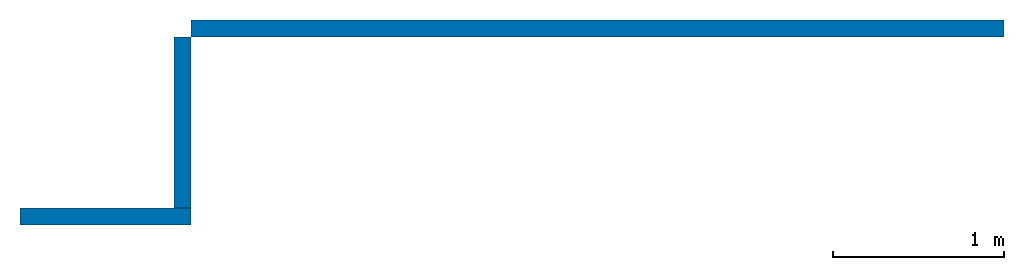
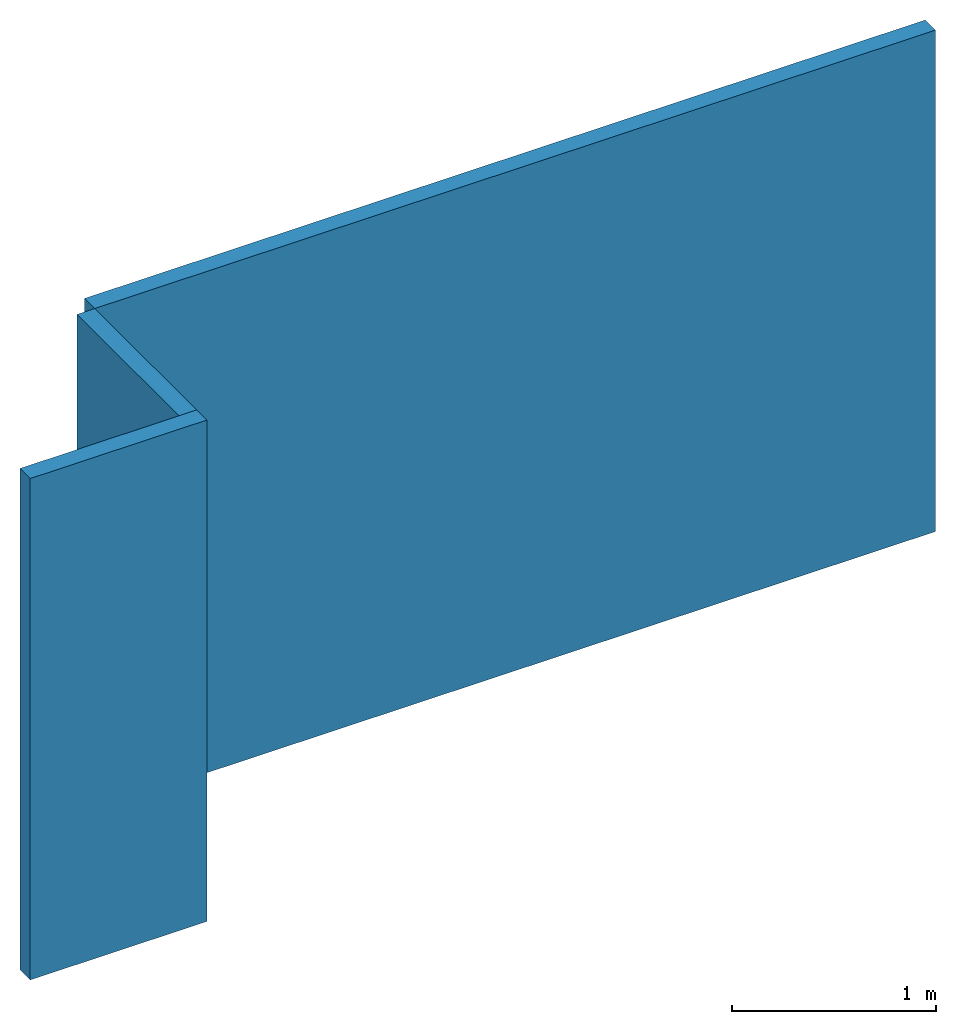
# One storey: 3 walls.
"""IFC4 building model written with IfcOpenShell, lengths in metres."""

from ifc_helpers import new_model, entity, si_unit, converted_unit, frame, origin_with_axes, origin_2d_with_axis, place, context, subcontext, project, spatial, indexed_curve, outline, extrude, material, layer, layer_set, layer_usage, type_object, element, save


model = new_model("IFC4")

# Units and contexts
model_context = context("Model", 3, precision=1e-05, world=origin_with_axes())
plan_context = context("Plan", 2, precision=1e-05, world=origin_2d_with_axis())
body_context = subcontext(model_context, "Body", "Model", "MODEL_VIEW")
ifc_project = project(units=[si_unit("LENGTHUNIT", "METRE"), converted_unit("PLANEANGLEUNIT", "degree", entity("IfcReal", 0.0174532925199433), si_unit("PLANEANGLEUNIT", "RADIAN"), dimensions=[0, 0, 0, 0, 0, 0, 0]), si_unit("AREAUNIT", "SQUARE_METRE"), si_unit("VOLUMEUNIT", "CUBIC_METRE")], contexts=[model_context, plan_context])

# Site, building, storey
site_placement = place(None, origin_with_axes())
site = spatial("IfcSite", under=ifc_project, at=site_placement)
building_placement = place(site_placement, origin_with_axes())
building = spatial("IfcBuilding", under=site, at=building_placement, Name="Building")
storey_placement = place(building_placement, origin_with_axes())
storey = spatial("IfcBuildingStorey", under=building, at=storey_placement, Name="Storey")

# Walls
ifc_material = material()
ifc_layer = layer(ifc_material, 0.1)
ifc_layer_set = layer_set([ifc_layer])
ifc_layer_usage_1 = layer_usage(ifc_layer_set, "AXIS2", "POSITIVE", 0.0)
wall_type = type_object("IfcWallType", Name="WAL100", PredefinedType="NOTDEFINED", material=ifc_layer_set)
wall_1_placement = place(storey_placement, origin_with_axes())
element("IfcWall", 1, at=wall_1_placement, inside=storey, type_object=wall_type, material=ifc_layer_usage_1, Name="Wall", context=body_context, shape_type="SweptSolid", body=[
    extrude(outline(indexed_curve([(0.0, 0.0), (0.0, 0.1), (1.0, 0.1), (1.0, 0.0), (0.0, 0.0)], self_intersect=False)), origin_with_axes(), (0.0, 0.0, 1.0), 3.0),
])
ifc_layer_usage_2 = layer_usage(ifc_layer_set, "AXIS2", "POSITIVE", 0.0)
wall_2_placement = place(storey_placement, frame((1.0, 0.0999999940395355, 0.0), z_axis=(0.0, 0.0, 1.0), x_axis=(7.54979012640431e-08, 0.999999999999997, 0.0)))
element("IfcWall", 2, at=wall_2_placement, inside=storey, type_object=wall_type, material=ifc_layer_usage_2, Name="Wall", context=body_context, shape_type="SweptSolid", body=[
    extrude(outline(indexed_curve([(0.0, 0.0), (0.0, 0.1), (1.0, 0.1), (1.0, 0.0), (0.0, 0.0)], self_intersect=False)), origin_with_axes(), (0.0, 0.0, 1.0), 3.0),
])
ifc_layer_usage_3 = layer_usage(ifc_layer_set, "AXIS2", "POSITIVE", 0.0)
wall_3_placement = place(storey_placement, frame((1.00000023841858, 1.10000002384186, 0.0), z_axis=(0.0, 0.0, 1.0), x_axis=(0.999999999999936, -3.57627868652321e-07, 0.0)))
element("IfcWall", 3, at=wall_3_placement, inside=storey, type_object=wall_type, material=ifc_layer_usage_3, Name="Wall", PredefinedType="MOVABLE", context=body_context, shape_type="SweptSolid", body=[
    extrude(outline(indexed_curve([(0.0, 0.0), (0.0, 0.1), (4.75816827455506, 0.1), (4.75816827455506, 0.0), (0.0, 0.0)], self_intersect=False)), origin_with_axes(), (0.0, 0.0, 1.0), 3.0),
])

save(model, "model.ifc")
